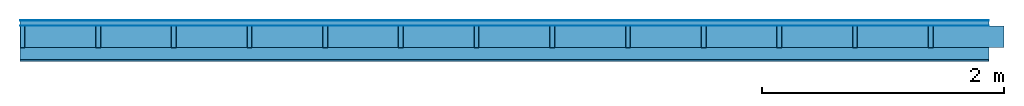
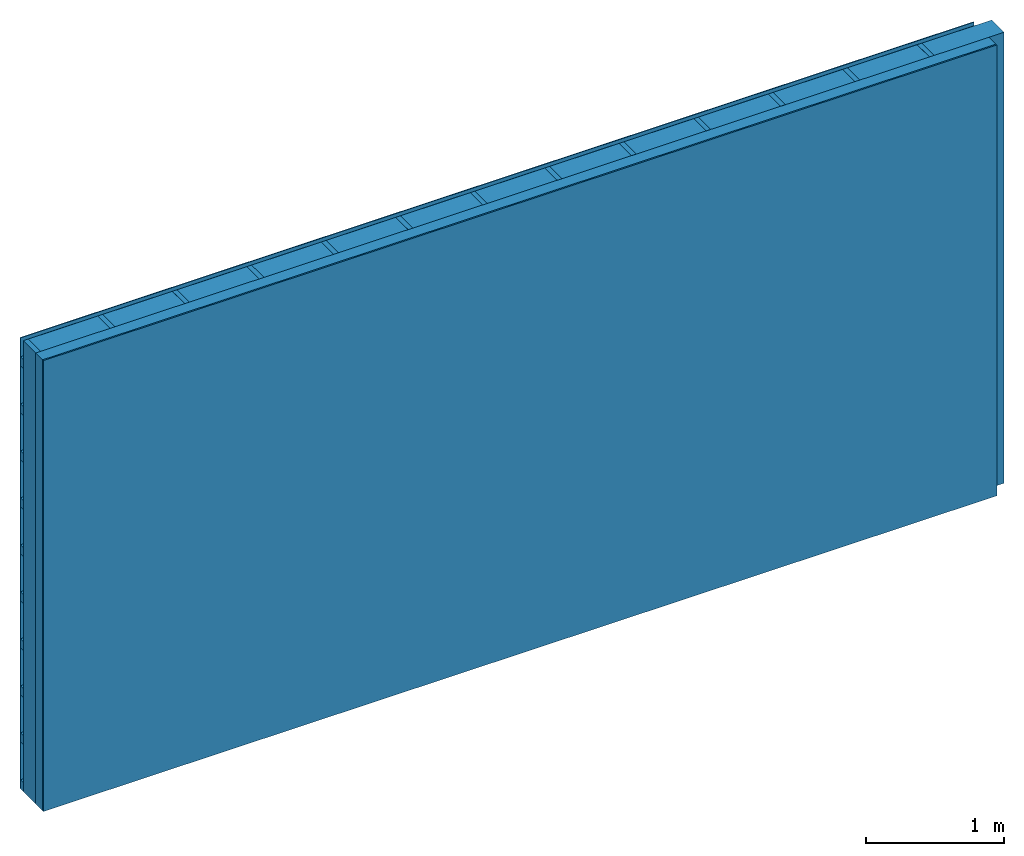
# One storey: 4 plates, 3 members, 1 element without a shape of its own.
"""IFC4 building model written with IfcOpenShell, lengths in metres."""

import ifcopenshell
import ifcopenshell.guid

model = None  # the IFC model being written
_history = None  # IfcOwnerHistory: only IFC2X3 demands one
_inside = {}  # id of a spatial element -> (the spatial element, [elements in it])
_under = {}  # id of a project, library or spatial element -> (it, [spatial elements below it])
_declared = {}  # id of a project -> (the project, [libraries it declares])
_typed = {}  # id of a type object -> (the type object, [elements of that type])
_made_of = {}  # id of a material, layer set ... -> (it, [elements and type objects made of it])


def new_model(schema):
    """Start an empty IFC model of exactly this schema.

    Asked for "IFC4X3", IfcOpenShell would pick the latest addendum, in which some entities
    have other attributes; the version numbers below select the first issue.
    IFC2X3 requires an IfcOwnerHistory on every rooted entity: one is made here for all.
    """
    global model, _history
    if schema == "IFC4X3":
        model = ifcopenshell.file(schema_version=(4, 3, 0, 0))
    else:
        model = ifcopenshell.file(schema=schema)
    _inside.clear()
    _under.clear()
    _declared.clear()
    _typed.clear()
    _made_of.clear()
    _history = None
    if model.schema == "IFC2X3":
        org = make("IfcOrganization", Name="unknown")
        user = make(
            "IfcPersonAndOrganization",
            ThePerson=make("IfcPerson", FamilyName="unknown"),
            TheOrganization=org,
        )
        app = make(
            "IfcApplication",
            ApplicationDeveloper=org,
            Version="unknown",
            ApplicationFullName="unknown",
            ApplicationIdentifier="unknown",
        )
        _history = make(
            "IfcOwnerHistory",
            OwningUser=user,
            OwningApplication=app,
            ChangeAction="ADDED",
            CreationDate=0,
        )
    return model


def make(cls, **values):
    """One entity of the class cls with the attributes given. An attribute that is None is left unset."""
    return model.create_entity(
        cls, **{name: value for name, value in values.items() if value is not None}
    )


def rooted(cls, **values):
    """An entity with a GlobalId (a new one), such as an element, a storey or a relation."""
    return make(cls, GlobalId=ifcopenshell.guid.new(), OwnerHistory=_history, **values)


def si_unit(unit_type, name, prefix=None):
    """IfcSIUnit, for example si_unit("LENGTHUNIT", "METRE", prefix="MILLI")."""
    return make("IfcSIUnit", UnitType=unit_type, Prefix=prefix, Name=name)


def derived_unit(unit_type, elements):
    """IfcDerivedUnit: a product of units, each with its exponent."""
    return make(
        "IfcDerivedUnit",
        Elements=[
            make("IfcDerivedUnitElement", Unit=unit, Exponent=power)
            for unit, power in elements
        ],
        UnitType=unit_type,
    )


def assignment(units):
    """IfcUnitAssignment: the units of a project."""
    return None if units is None else make("IfcUnitAssignment", Units=units)


def point(xyz):
    """IfcCartesianPoint."""
    return None if xyz is None else make("IfcCartesianPoint", Coordinates=xyz)


def direction(xyz):
    """IfcDirection."""
    return None if xyz is None else make("IfcDirection", DirectionRatios=xyz)


def frame(location, z_axis=None, x_axis=None):
    """IfcAxis2Placement3D, a coordinate frame: its origin and axes. An axis left out is left unset."""
    return make(
        "IfcAxis2Placement3D",
        Location=point(location),
        Axis=direction(z_axis),
        RefDirection=direction(x_axis),
    )


def frame_2d(location, x_axis=None):
    """IfcAxis2Placement2D, a coordinate frame in the plane: its origin and x axis."""
    return make(
        "IfcAxis2Placement2D", Location=point(location), RefDirection=direction(x_axis)
    )


def origin():
    """The frame at (0, 0, 0) with its axes left unset."""
    return frame((0.0, 0.0, 0.0))


def origin_with_axes():
    """The frame at (0, 0, 0) with the z axis (0, 0, 1) and the x axis (1, 0, 0) written out."""
    return frame((0.0, 0.0, 0.0), z_axis=(0.0, 0.0, 1.0), x_axis=(1.0, 0.0, 0.0))


def place(relative_to, where):
    """IfcLocalPlacement: puts the frame where relative to a parent placement (None: the world)."""
    return make(
        "IfcLocalPlacement", PlacementRelTo=relative_to, RelativePlacement=where
    )


def context(
    kind, dimensions, precision=None, world=None, true_north=None, identifier=None
):
    """IfcGeometricRepresentationContext, for example the 3D "Model" context."""
    return make(
        "IfcGeometricRepresentationContext",
        ContextIdentifier=identifier,
        ContextType=kind,
        CoordinateSpaceDimension=dimensions,
        Precision=precision,
        WorldCoordinateSystem=world,
        TrueNorth=true_north,
    )


def project(units=None, contexts=None):
    """IfcProject with its units and contexts."""
    return rooted(
        "IfcProject",
        Name="project",
        RepresentationContexts=contexts,
        UnitsInContext=assignment(units),
    )


def spatial(cls, under=None, at=None, **own):
    """A site, building, storey or space (cls), placed at a placement, below another one or the project."""
    s = rooted(cls, ObjectPlacement=at, **own)
    if under is not None:
        _under.setdefault(under.id(), (under, []))[1].append(s)
    return s


def profile(cls, at=None, kind="AREA", **sizes):
    """A parametric profile (cls). Its sizes go by their IFC names, for example OverallWidth=200.0."""
    return make(cls, ProfileType=kind, Position=at, **sizes)


def rectangle(**sizes):
    """IfcRectangleProfileDef."""
    return profile("IfcRectangleProfileDef", **sizes)


def extrude(swept, where, along, depth):
    """IfcExtrudedAreaSolid: the profile swept, set in the frame where, extruded along a direction by depth."""
    return make(
        "IfcExtrudedAreaSolid",
        SweptArea=swept,
        Position=where,
        ExtrudedDirection=direction(along),
        Depth=depth,
    )


def shape(context_of_items, identifier, shape_type, items):
    """IfcShapeRepresentation: the items that make up one representation, for example the "Body"."""
    return make(
        "IfcShapeRepresentation",
        ContextOfItems=context_of_items,
        RepresentationIdentifier=identifier,
        RepresentationType=shape_type,
        Items=items,
    )


def material(Name=None, Category=None):
    """IfcMaterial."""
    return make("IfcMaterial", Name=Name, Category=Category)


def layer(
    of_material, thickness, ventilated=None, Name=None, Category=None, Priority=None
):
    """IfcMaterialLayer: one layer of a wall or slab, of a material (None: an air gap)."""
    return make(
        "IfcMaterialLayer",
        Material=of_material,
        LayerThickness=thickness,
        IsVentilated=ventilated,
        Name=Name,
        Category=Category,
        Priority=Priority,
    )


def layer_set(layers, Name=None):
    """IfcMaterialLayerSet."""
    return make("IfcMaterialLayerSet", MaterialLayers=layers, LayerSetName=Name)


def made_of(thing, what):
    """Note that an element or type object is made of a material, layer set ...; save() writes the relation."""
    if what is not None:
        _made_of.setdefault(what.id(), (what, []))[1].append(thing)
    return thing


def type_object(cls, material=None, **own):
    """A type object (cls), such as IfcWallType, which elements share."""
    return made_of(rooted(cls, **own), material)


def element(
    cls,
    number,
    at=None,
    inside=None,
    cuts=None,
    type_object=None,
    material=None,
    context=None,
    identifier="Body",
    shape_type=None,
    held_by="IfcProductDefinitionShape",
    body=None,
    shapes=None,
    **own,
):
    """One element of the class cls, such as IfcWall. Its Tag is "e" and its number.

    at: its placement. inside: the storey or other place that contains it. cuts: it is an
    opening in that element (IfcRelVoidsElement). A single representation is given by context,
    identifier, shape_type and body (its items); several are given by shapes. held_by: the class
    of the entity that holds the representations. save() writes the other relations.
    """
    e = rooted(cls, Tag="e%d" % number, ObjectPlacement=at, **own)
    if body is not None:
        shapes = [shape(context, identifier, shape_type, body)]
    if shapes is not None:
        e.Representation = make(held_by, Representations=shapes)
    if inside is not None:
        _inside.setdefault(inside.id(), (inside, []))[1].append(e)
    if cuts is not None:
        rooted(
            "IfcRelVoidsElement", RelatingBuildingElement=cuts, RelatedOpeningElement=e
        )
    if type_object is not None:
        _typed.setdefault(type_object.id(), (type_object, []))[1].append(e)
    return made_of(e, material)


def aggregate(whole, parts):
    """IfcRelAggregates: a whole, such as a stair, and the parts it consists of."""
    return rooted("IfcRelAggregates", RelatingObject=whole, RelatedObjects=parts)


def save(model, path):
    """Write the relations noted so far, then the file.

    IfcRelAggregates (storeys below a building ...), IfcRelContainedInSpatialStructure (elements
    in a storey), IfcRelDefinesByType, IfcRelAssociatesMaterial and IfcRelDeclares: one each for
    every whole, place, type object, material and project.
    """
    for whole, parts in _under.values():
        aggregate(whole, parts)
    for where, things in _inside.values():
        rooted(
            "IfcRelContainedInSpatialStructure",
            RelatedElements=things,
            RelatingStructure=where,
        )
    for kind, things in _typed.values():
        rooted("IfcRelDefinesByType", RelatedObjects=things, RelatingType=kind)
    for what, things in _made_of.values():
        rooted("IfcRelAssociatesMaterial", RelatedObjects=things, RelatingMaterial=what)
    for by, libraries in _declared.values():
        rooted("IfcRelDeclares", RelatingContext=by, RelatedDefinitions=libraries)
    model.write(path)


model = new_model("IFC4")

# Units and contexts
plan_context = context("Plan", 3, precision=1e-05, world=origin(), true_north=direction((0.0, 1.0)))
model_context = context("Model", 3, precision=1e-05, world=origin(), true_north=direction((0.0, 1.0)))
ifc_project = project(units=[si_unit("LENGTHUNIT", "METRE"), derived_unit("SOUNDPRESSUREUNIT", [(si_unit("PRESSUREUNIT", "PASCAL", prefix="MICRO"), 0)]), si_unit("ENERGYUNIT", "JOULE", prefix="MEGA"), si_unit("MASSUNIT", "GRAM", prefix="KILO"), derived_unit("THERMALTRANSMITTANCEUNIT", [(si_unit("POWERUNIT", "WATT"), 1), (si_unit("AREAUNIT", "SQUARE_METRE"), -1), (si_unit("THERMODYNAMICTEMPERATUREUNIT", "KELVIN"), -1)]), derived_unit("AREADENSITYUNIT", [(si_unit("MASSUNIT", "GRAM", prefix="KILO"), 1), (si_unit("AREAUNIT", "SQUARE_METRE"), -1)]), derived_unit("USERDEFINED", [(si_unit("ENERGYUNIT", "JOULE", prefix="MEGA"), 1), (si_unit("AREAUNIT", "SQUARE_METRE"), -1)])], contexts=[plan_context, model_context])

# Site, building, storey
site = spatial("IfcSite", under=ifc_project)
building_placement = place(None, origin())
building = spatial("IfcBuilding", under=site, at=building_placement)
storey_placement = place(building_placement, origin())
storey = spatial("IfcBuildingStorey", under=building, at=storey_placement)

# Wall, members, plates
ifc_material_1 = material(Name="mineral, cement-based building board", Category="03.003")
ifc_layer_1 = layer(ifc_material_1, 0.008, Name="Cover 1st layer")
ifc_layer_2 = layer(None, 0.04, Name="Battens / profiles (ventilation)")
ifc_material_2 = material(Name="Vapor-permeable water barrier", Category="09.006")
ifc_layer_3 = layer(ifc_material_2, 0.0005, Name="outside 1st layer")
ifc_material_3 = material(Name="of the art")
ifc_layer_4 = layer(ifc_material_3, 0.0, Name="Bond")
ifc_layer_5 = layer(None, 0.18, Name="Support")
ifc_layer_6 = layer(ifc_material_3, 0.0, Name="Bond")
ifc_material_4 = material(Name="Solid timber panel")
ifc_layer_7 = layer(ifc_material_4, 0.1, Name="1st layer")
ifc_material_5 = material(Name="Plasterboard type A", Category="03.008")
ifc_layer_8 = layer(ifc_material_5, 0.0125, Name="Covering 1st layer")
ifc_material_6 = material(Name="joints", Category="04.017")
ifc_layer_9 = layer(ifc_material_6, 0.0, Name="Surface")
ifc_layer_set = layer_set([ifc_layer_1, ifc_layer_2, ifc_layer_3, ifc_layer_4, ifc_layer_5, ifc_layer_6, ifc_layer_7, ifc_layer_8, ifc_layer_9])
wall_type = type_object("IfcWallType", Name="D1000", PredefinedType="NOTDEFINED", material=ifc_layer_set)
wall_placement = place(None, frame((0.0, 0.0, 0.0), z_axis=(0.0, -1.0, 0.0), x_axis=(1.0, 0.0, 0.0)))
wall = element("IfcWall", 1, at=wall_placement, inside=storey, type_object=wall_type, material=ifc_layer_set, Name="Wall #1")
ifc_material_7 = material()
member_1_placement = place(wall_placement, origin())
member_1 = element("IfcMember", 2, at=member_1_placement, material=ifc_material_7, Name="Battens / profiles (ventilation)", context=plan_context, shape_type="SweptSolid", body=[
    extrude(rectangle(XDim=0.08, YDim=0.04, at=frame_2d((0.04, 0.02), x_axis=(1.0, 0.0))), frame((0.0, 0.0, 0.008), z_axis=(1.0, 0.0, 0.0), x_axis=(0.0, 1.0, 0.0)), (0.0, 0.0, 1.0), 8.0),
    extrude(rectangle(XDim=0.08, YDim=0.04, at=frame_2d((0.04, 0.02), x_axis=(1.0, 0.0))), frame((0.0, 0.417, 0.008), z_axis=(1.0, 0.0, 0.0), x_axis=(0.0, 1.0, 0.0)), (0.0, 0.0, 1.0), 8.0),
    extrude(rectangle(XDim=0.08, YDim=0.04, at=frame_2d((0.04, 0.02), x_axis=(1.0, 0.0))), frame((0.0, 0.834, 0.008), z_axis=(1.0, 0.0, 0.0), x_axis=(0.0, 1.0, 0.0)), (0.0, 0.0, 1.0), 8.0),
    extrude(rectangle(XDim=0.08, YDim=0.04, at=frame_2d((0.04, 0.02), x_axis=(1.0, 0.0))), frame((0.0, 1.251, 0.008), z_axis=(1.0, 0.0, 0.0), x_axis=(0.0, 1.0, 0.0)), (0.0, 0.0, 1.0), 8.0),
    extrude(rectangle(XDim=0.08, YDim=0.04, at=frame_2d((0.04, 0.02), x_axis=(1.0, 0.0))), frame((0.0, 1.668, 0.008), z_axis=(1.0, 0.0, 0.0), x_axis=(0.0, 1.0, 0.0)), (0.0, 0.0, 1.0), 8.0),
    extrude(rectangle(XDim=0.08, YDim=0.04, at=frame_2d((0.04, 0.02), x_axis=(1.0, 0.0))), frame((0.0, 2.085, 0.008), z_axis=(1.0, 0.0, 0.0), x_axis=(0.0, 1.0, 0.0)), (0.0, 0.0, 1.0), 8.0),
    extrude(rectangle(XDim=0.08, YDim=0.04, at=frame_2d((0.04, 0.02), x_axis=(1.0, 0.0))), frame((0.0, 2.502, 0.008), z_axis=(1.0, 0.0, 0.0), x_axis=(0.0, 1.0, 0.0)), (0.0, 0.0, 1.0), 8.0),
    extrude(rectangle(XDim=0.08, YDim=0.04, at=frame_2d((0.04, 0.02), x_axis=(1.0, 0.0))), frame((0.0, 2.919, 0.008), z_axis=(1.0, 0.0, 0.0), x_axis=(0.0, 1.0, 0.0)), (0.0, 0.0, 1.0), 8.0),
    extrude(rectangle(XDim=0.08, YDim=0.04, at=frame_2d((0.04, 0.02), x_axis=(1.0, 0.0))), frame((0.0, 3.336, 0.008), z_axis=(1.0, 0.0, 0.0), x_axis=(0.0, 1.0, 0.0)), (0.0, 0.0, 1.0), 8.0),
    extrude(rectangle(XDim=0.08, YDim=0.04, at=frame_2d((0.04, 0.02), x_axis=(1.0, 0.0))), frame((0.0, 3.753, 0.008), z_axis=(1.0, 0.0, 0.0), x_axis=(0.0, 1.0, 0.0)), (0.0, 0.0, 1.0), 8.0),
])
ifc_material_8 = material()
member_2_placement = place(wall_placement, origin())
member_2 = element("IfcMember", 3, at=member_2_placement, material=ifc_material_8, Name="Support", context=plan_context, shape_type="SweptSolid", body=[
    extrude(rectangle(XDim=0.04, YDim=0.18, at=frame_2d((0.02, 0.09), x_axis=(1.0, 0.0))), frame((0.0, 4.0, 0.0485), z_axis=(0.0, -1.0, 0.0), x_axis=(1.0, 0.0, 0.0)), (0.0, 0.0, 1.0), 4.0),
    extrude(rectangle(XDim=0.04, YDim=0.18, at=frame_2d((0.02, 0.09), x_axis=(1.0, 0.0))), frame((0.625, 4.0, 0.0485), z_axis=(0.0, -1.0, 0.0), x_axis=(1.0, 0.0, 0.0)), (0.0, 0.0, 1.0), 4.0),
    extrude(rectangle(XDim=0.04, YDim=0.18, at=frame_2d((0.02, 0.09), x_axis=(1.0, 0.0))), frame((1.25, 4.0, 0.0485), z_axis=(0.0, -1.0, 0.0), x_axis=(1.0, 0.0, 0.0)), (0.0, 0.0, 1.0), 4.0),
    extrude(rectangle(XDim=0.04, YDim=0.18, at=frame_2d((0.02, 0.09), x_axis=(1.0, 0.0))), frame((1.875, 4.0, 0.0485), z_axis=(0.0, -1.0, 0.0), x_axis=(1.0, 0.0, 0.0)), (0.0, 0.0, 1.0), 4.0),
    extrude(rectangle(XDim=0.04, YDim=0.18, at=frame_2d((0.02, 0.09), x_axis=(1.0, 0.0))), frame((2.5, 4.0, 0.0485), z_axis=(0.0, -1.0, 0.0), x_axis=(1.0, 0.0, 0.0)), (0.0, 0.0, 1.0), 4.0),
    extrude(rectangle(XDim=0.04, YDim=0.18, at=frame_2d((0.02, 0.09), x_axis=(1.0, 0.0))), frame((3.125, 4.0, 0.0485), z_axis=(0.0, -1.0, 0.0), x_axis=(1.0, 0.0, 0.0)), (0.0, 0.0, 1.0), 4.0),
    extrude(rectangle(XDim=0.04, YDim=0.18, at=frame_2d((0.02, 0.09), x_axis=(1.0, 0.0))), frame((3.75, 4.0, 0.0485), z_axis=(0.0, -1.0, 0.0), x_axis=(1.0, 0.0, 0.0)), (0.0, 0.0, 1.0), 4.0),
    extrude(rectangle(XDim=0.04, YDim=0.18, at=frame_2d((0.02, 0.09), x_axis=(1.0, 0.0))), frame((4.375, 4.0, 0.0485), z_axis=(0.0, -1.0, 0.0), x_axis=(1.0, 0.0, 0.0)), (0.0, 0.0, 1.0), 4.0),
    extrude(rectangle(XDim=0.04, YDim=0.18, at=frame_2d((0.02, 0.09), x_axis=(1.0, 0.0))), frame((5.0, 4.0, 0.0485), z_axis=(0.0, -1.0, 0.0), x_axis=(1.0, 0.0, 0.0)), (0.0, 0.0, 1.0), 4.0),
    extrude(rectangle(XDim=0.04, YDim=0.18, at=frame_2d((0.02, 0.09), x_axis=(1.0, 0.0))), frame((5.625, 4.0, 0.0485), z_axis=(0.0, -1.0, 0.0), x_axis=(1.0, 0.0, 0.0)), (0.0, 0.0, 1.0), 4.0),
    extrude(rectangle(XDim=0.04, YDim=0.18, at=frame_2d((0.02, 0.09), x_axis=(1.0, 0.0))), frame((6.25, 4.0, 0.0485), z_axis=(0.0, -1.0, 0.0), x_axis=(1.0, 0.0, 0.0)), (0.0, 0.0, 1.0), 4.0),
    extrude(rectangle(XDim=0.04, YDim=0.18, at=frame_2d((0.02, 0.09), x_axis=(1.0, 0.0))), frame((6.875, 4.0, 0.0485), z_axis=(0.0, -1.0, 0.0), x_axis=(1.0, 0.0, 0.0)), (0.0, 0.0, 1.0), 4.0),
    extrude(rectangle(XDim=0.04, YDim=0.18, at=frame_2d((0.02, 0.09), x_axis=(1.0, 0.0))), frame((7.5, 4.0, 0.0485), z_axis=(0.0, -1.0, 0.0), x_axis=(1.0, 0.0, 0.0)), (0.0, 0.0, 1.0), 4.0),
])
ifc_material_9 = material(Name="Mineral wool")
member_3_placement = place(wall_placement, origin())
member_3 = element("IfcMember", 4, at=member_3_placement, material=ifc_material_9, Name="Cavity", context=plan_context, shape_type="SweptSolid", body=[
    extrude(rectangle(XDim=0.585, YDim=0.18, at=frame_2d((0.2925, 0.09), x_axis=(1.0, 0.0))), frame((0.04, 4.0, 0.0485), z_axis=(0.0, -1.0, 0.0), x_axis=(1.0, 0.0, 0.0)), (0.0, 0.0, 1.0), 4.0),
    extrude(rectangle(XDim=0.585, YDim=0.18, at=frame_2d((0.2925, 0.09), x_axis=(1.0, 0.0))), frame((0.665, 4.0, 0.0485), z_axis=(0.0, -1.0, 0.0), x_axis=(1.0, 0.0, 0.0)), (0.0, 0.0, 1.0), 4.0),
    extrude(rectangle(XDim=0.585, YDim=0.18, at=frame_2d((0.2925, 0.09), x_axis=(1.0, 0.0))), frame((1.29, 4.0, 0.0485), z_axis=(0.0, -1.0, 0.0), x_axis=(1.0, 0.0, 0.0)), (0.0, 0.0, 1.0), 4.0),
    extrude(rectangle(XDim=0.585, YDim=0.18, at=frame_2d((0.2925, 0.09), x_axis=(1.0, 0.0))), frame((1.915, 4.0, 0.0485), z_axis=(0.0, -1.0, 0.0), x_axis=(1.0, 0.0, 0.0)), (0.0, 0.0, 1.0), 4.0),
    extrude(rectangle(XDim=0.585, YDim=0.18, at=frame_2d((0.2925, 0.09), x_axis=(1.0, 0.0))), frame((2.54, 4.0, 0.0485), z_axis=(0.0, -1.0, 0.0), x_axis=(1.0, 0.0, 0.0)), (0.0, 0.0, 1.0), 4.0),
    extrude(rectangle(XDim=0.585, YDim=0.18, at=frame_2d((0.2925, 0.09), x_axis=(1.0, 0.0))), frame((3.165, 4.0, 0.0485), z_axis=(0.0, -1.0, 0.0), x_axis=(1.0, 0.0, 0.0)), (0.0, 0.0, 1.0), 4.0),
    extrude(rectangle(XDim=0.585, YDim=0.18, at=frame_2d((0.2925, 0.09), x_axis=(1.0, 0.0))), frame((3.79, 4.0, 0.0485), z_axis=(0.0, -1.0, 0.0), x_axis=(1.0, 0.0, 0.0)), (0.0, 0.0, 1.0), 4.0),
    extrude(rectangle(XDim=0.585, YDim=0.18, at=frame_2d((0.2925, 0.09), x_axis=(1.0, 0.0))), frame((4.415, 4.0, 0.0485), z_axis=(0.0, -1.0, 0.0), x_axis=(1.0, 0.0, 0.0)), (0.0, 0.0, 1.0), 4.0),
    extrude(rectangle(XDim=0.585, YDim=0.18, at=frame_2d((0.2925, 0.09), x_axis=(1.0, 0.0))), frame((5.04, 4.0, 0.0485), z_axis=(0.0, -1.0, 0.0), x_axis=(1.0, 0.0, 0.0)), (0.0, 0.0, 1.0), 4.0),
    extrude(rectangle(XDim=0.585, YDim=0.18, at=frame_2d((0.2925, 0.09), x_axis=(1.0, 0.0))), frame((5.665, 4.0, 0.0485), z_axis=(0.0, -1.0, 0.0), x_axis=(1.0, 0.0, 0.0)), (0.0, 0.0, 1.0), 4.0),
    extrude(rectangle(XDim=0.585, YDim=0.18, at=frame_2d((0.2925, 0.09), x_axis=(1.0, 0.0))), frame((6.29, 4.0, 0.0485), z_axis=(0.0, -1.0, 0.0), x_axis=(1.0, 0.0, 0.0)), (0.0, 0.0, 1.0), 4.0),
    extrude(rectangle(XDim=0.585, YDim=0.18, at=frame_2d((0.2925, 0.09), x_axis=(1.0, 0.0))), frame((6.915, 4.0, 0.0485), z_axis=(0.0, -1.0, 0.0), x_axis=(1.0, 0.0, 0.0)), (0.0, 0.0, 1.0), 4.0),
    extrude(rectangle(XDim=0.585, YDim=0.18, at=frame_2d((0.2925, 0.09), x_axis=(1.0, 0.0))), frame((7.54, 4.0, 0.0485), z_axis=(0.0, -1.0, 0.0), x_axis=(1.0, 0.0, 0.0)), (0.0, 0.0, 1.0), 4.0),
])
plate_1_placement = place(wall_placement, origin())
plate_1 = element("IfcPlate", 5, at=plate_1_placement, material=ifc_material_1, Name="Cover 1st layer", context=plan_context, shape_type="SweptSolid", body=[
    extrude(rectangle(XDim=8.0, YDim=4.0, at=frame_2d((4.0, 2.0), x_axis=(1.0, 0.0))), origin_with_axes(), (0.0, 0.0, 1.0), 0.008),
])
plate_2_placement = place(wall_placement, origin())
plate_2 = element("IfcPlate", 6, at=plate_2_placement, material=ifc_material_2, Name="outside 1st layer", context=plan_context, shape_type="SweptSolid", body=[
    extrude(rectangle(XDim=8.0, YDim=4.0, at=frame_2d((4.0, 2.0), x_axis=(1.0, 0.0))), frame((0.0, 0.0, 0.048), z_axis=(0.0, 0.0, 1.0), x_axis=(1.0, 0.0, 0.0)), (0.0, 0.0, 1.0), 0.0005),
])
plate_3_placement = place(wall_placement, origin())
plate_3 = element("IfcPlate", 7, at=plate_3_placement, material=ifc_material_4, Name="1st layer", context=plan_context, shape_type="SweptSolid", body=[
    extrude(rectangle(XDim=8.0, YDim=4.0, at=frame_2d((4.0, 2.0), x_axis=(1.0, 0.0))), frame((0.0, 0.0, 0.2285), z_axis=(0.0, 0.0, 1.0), x_axis=(1.0, 0.0, 0.0)), (0.0, 0.0, 1.0), 0.1),
])
plate_4_placement = place(wall_placement, origin())
plate_4 = element("IfcPlate", 8, at=plate_4_placement, material=ifc_material_5, Name="Covering 1st layer", context=plan_context, shape_type="SweptSolid", body=[
    extrude(rectangle(XDim=8.0, YDim=4.0, at=frame_2d((4.0, 2.0), x_axis=(1.0, 0.0))), frame((0.0, 0.0, 0.3285), z_axis=(0.0, 0.0, 1.0), x_axis=(1.0, 0.0, 0.0)), (0.0, 0.0, 1.0), 0.0125),
])
aggregate(wall, [plate_1, member_1, plate_2, member_2, member_3, plate_3, plate_4])

save(model, "model.ifc")
